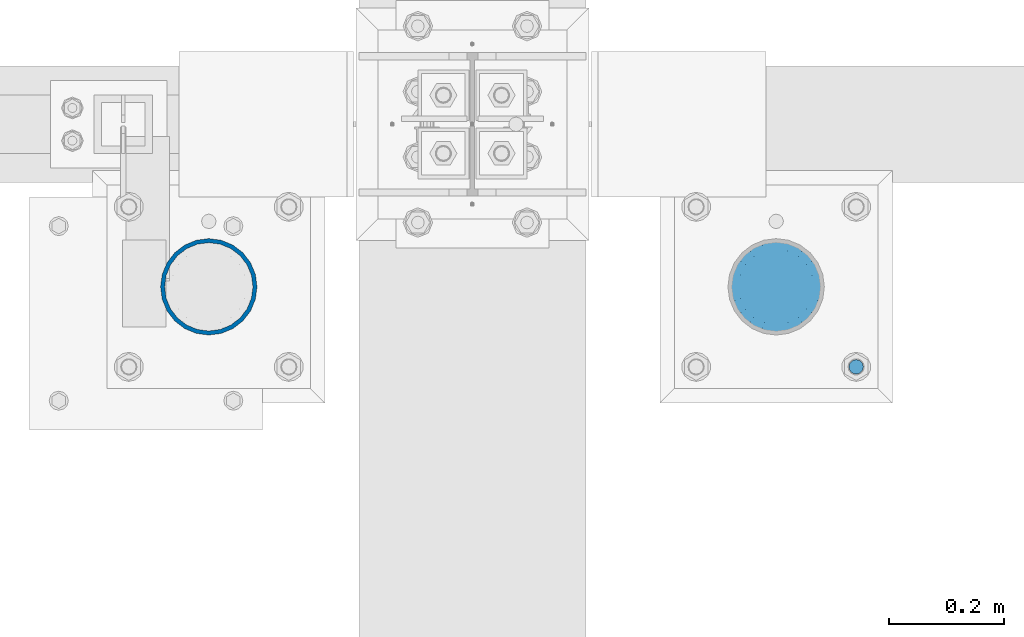
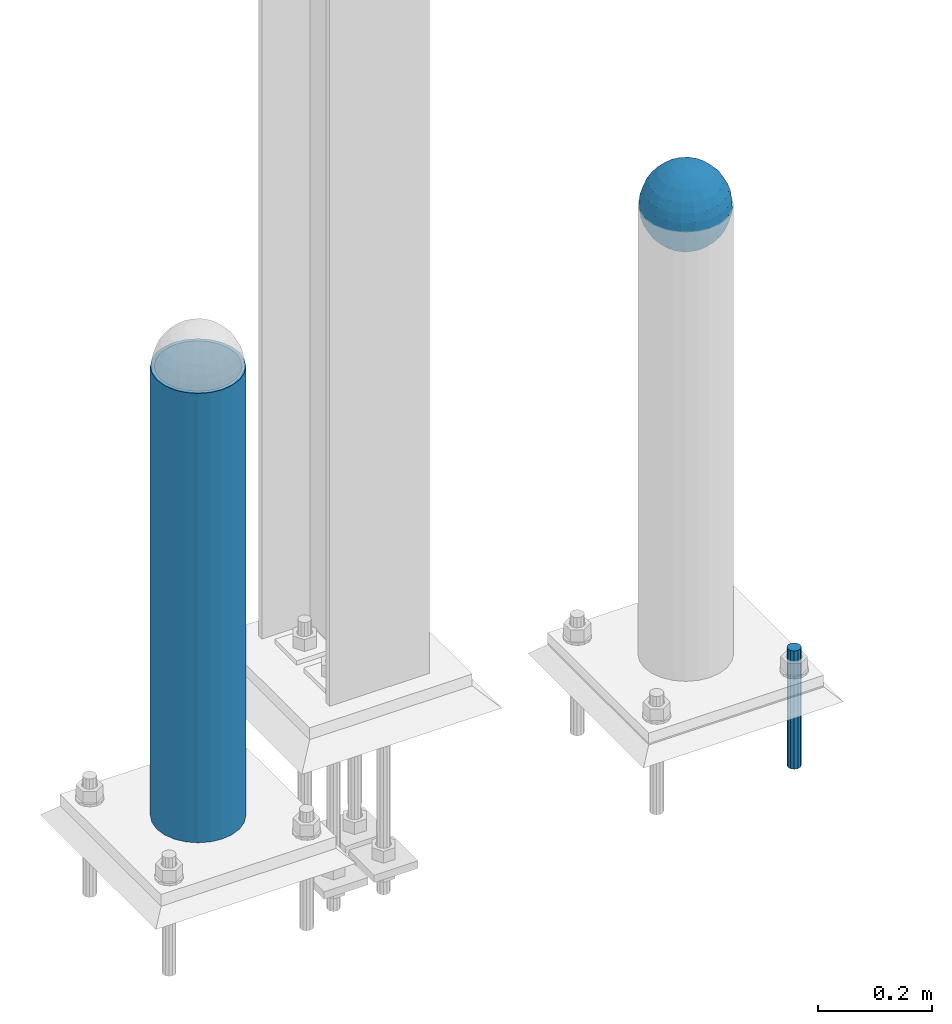
# One storey, part 1444 of 3843: 3 columns, 3 elements without a shape of their own.
"""IFC2X3 building model written with IfcOpenShell, lengths in millimetres."""

from ifc_helpers import new_model, si_unit, frame, origin_with_axes, place, context, subcontext, project, spatial, faceted_brep, material, type_object, element, aggregate, save


model = new_model("IFC2X3")

# Units and contexts
model_context = context("Model", 3, precision=1e-05, world=origin_with_axes())
body_context = subcontext(model_context, "Body", "Model", "MODEL_VIEW")
ifc_project = project(units=[si_unit("LENGTHUNIT", "METRE", prefix="MILLI"), si_unit("AREAUNIT", "SQUARE_METRE"), si_unit("VOLUMEUNIT", "CUBIC_METRE"), si_unit("MASSUNIT", "GRAM", prefix="KILO"), si_unit("TIMEUNIT", "SECOND"), si_unit("PLANEANGLEUNIT", "RADIAN"), si_unit("SOLIDANGLEUNIT", "STERADIAN"), si_unit("THERMODYNAMICTEMPERATUREUNIT", "DEGREE_CELSIUS"), si_unit("LUMINOUSINTENSITYUNIT", "LUMEN")], contexts=[model_context])

# Site, building, storey
site_placement = place(None, origin_with_axes())
site = spatial("IfcSite", under=ifc_project, at=site_placement, CompositionType="ELEMENT")
building_placement = place(site_placement, origin_with_axes())
building = spatial("IfcBuilding", under=site, at=building_placement, Name="Undefined", CompositionType="ELEMENT")
storey_placement = place(building_placement, origin_with_axes())
storey = spatial("IfcBuildingStorey", under=building, at=storey_placement, Name="Undefined", CompositionType="ELEMENT", Elevation=0.0)

# Assembly, column
assembly_1_placement = place(storey_placement, origin_with_axes())
assembly_1 = element("IfcElementAssembly", 1, at=assembly_1_placement, inside=storey, Name="CONC. FILL", AssemblyPlace="NOTDEFINED", PredefinedType="REINFORCEMENT_UNIT")
ifc_material_1 = material(Name="CONCRETE/1500")
column_type_1 = type_object("IfcColumnType", PredefinedType="NOTDEFINED")
column_1_placement = place(assembly_1_placement, frame((37106.2721557617, 14714.9457781578, 31411.8625), z_axis=(-1.0, 0.0, 0.0), x_axis=(0.0, 0.0, 1.0)))
column_1 = element("IfcColumn", 2, at=column_1_placement, type_object=column_type_1, material=ifc_material_1, Name="CONC. FILL", context=body_context, shape_type="Brep", body=[
    faceted_brep([(0.0, 0.0, 2.0), (0.0, -0.619999999995343, 1.89999999999964), (3.36549999999988, -7.1422259999963, 21.9814139999999), (3.36549999999988, 0.0, 23.1139999999996), (0.0, -1.17999999999302, 1.6200000000008), (3.36549999999988, -13.5910319999966, 18.6992260000006), (0.0, -1.61999999999534, 1.18000000000029), (3.36549999999988, -18.699225999997, 13.5910320000003), (0.0, -1.89999999999418, 0.6200000000008), (3.36549999999988, -21.9814139999944, 7.14222599999994), (0.0, -2.0, 0.0), (3.36549999999988, -23.1140000000014, 0.0), (0.0, -1.89999999999418, -0.6200000000008), (3.36549999999988, -21.9814139999944, -7.14222599999994), (0.0, -1.61999999999534, -1.18000000000029), (3.36549999999988, -18.699225999997, -13.5910320000003), (0.0, -1.17999999999302, -1.6200000000008), (3.36549999999988, -13.5910319999966, -18.6992260000006), (0.0, -0.619999999995343, -1.89999999999964), (3.36549999999988, -7.1422259999963, -21.9814139999999), (0.0, 0.0, -2.0), (3.36549999999988, 0.0, -23.1139999999996), (0.0, 0.619999999995343, -1.89999999999964), (3.36549999999988, 7.1422259999963, -21.9814139999999), (0.0, 1.17999999999302, -1.6200000000008), (3.36549999999988, 13.5910319999966, -18.6992260000006), (0.0, 1.61999999999534, -1.18000000000029), (3.36549999999988, 18.699225999997, -13.5910320000003), (0.0, 1.89999999999418, -0.6200000000008), (3.36549999999988, 21.9814139999944, -7.14222599999994), (0.0, 2.0, 0.0), (3.36549999999988, 23.1140000000014, 0.0), (0.0, 1.89999999999418, 0.6200000000008), (3.36549999999988, 21.9814139999944, 7.14222599999994), (0.0, 1.61999999999534, 1.18000000000029), (3.36549999999988, 18.699225999997, 13.5910320000003), (0.0, 1.17999999999302, 1.6200000000008), (3.36549999999988, 13.5910319999966, 18.6992260000006), (0.0, 0.619999999995343, 1.89999999999964), (3.36549999999988, 7.1422259999963, 21.9814139999999), (8.41374999999971, -11.1214661999984, 34.2282018000005), (8.41374999999971, 0.0, 35.9917999999998), (8.41374999999971, -21.1631784000056, 29.1173662000001), (8.41374999999971, -29.1173661999928, 21.1631784000001), (8.41374999999971, -34.2282017999969, 11.1214662000002), (8.41374999999971, -35.9918000000034, 0.0), (8.41374999999971, -34.2282017999969, -11.1214662000002), (8.41374999999971, -29.1173661999928, -21.1631784000001), (8.41374999999971, -21.1631784000056, -29.1173662000001), (8.41374999999971, -11.1214661999984, -34.2282018000005), (8.41374999999971, 0.0, -35.9917999999998), (8.41374999999971, 11.1214661999984, -34.2282018000005), (8.41374999999971, 21.1631784000056, -29.1173662000001), (8.41374999999971, 29.1173661999928, -21.1631784000001), (8.41374999999971, 34.2282017999969, -11.1214662000002), (8.41374999999971, 35.9918000000034, 0.0), (8.41374999999971, 34.2282017999969, 11.1214662000002), (8.41374999999971, 29.1173661999928, 21.1631784000001), (8.41374999999971, 21.1631784000056, 29.1173662000001), (8.41374999999971, 11.1214661999984, 34.2282018000005), (16.8274999999994, -15.3047700000025, 47.1030300000002), (16.8274999999994, 0.0, 49.5300000000007), (16.8274999999994, -29.1236400000053, 40.0697700000001), (16.8274999999994, -40.0697700000019, 29.1236399999998), (16.8274999999994, -47.1030299999984, 15.3047700000006), (16.8274999999994, -49.5299999999988, 0.0), (16.8274999999994, -47.1030299999984, -15.3047700000006), (16.8274999999994, -40.0697700000019, -29.1236399999998), (16.8274999999994, -29.1236400000053, -40.0697700000001), (16.8274999999994, -15.3047700000025, -47.1030300000002), (16.8274999999994, 0.0, -49.5300000000007), (16.8274999999994, 15.3047700000025, -47.1030300000002), (16.8274999999994, 29.1236400000053, -40.0697700000001), (16.8274999999994, 40.0697700000019, -29.1236399999998), (16.8274999999994, 47.1030299999984, -15.3047700000006), (16.8274999999994, 49.5299999999988, 0.0), (16.8274999999994, 47.1030299999984, 15.3047700000006), (16.8274999999994, 40.0697700000019, 29.1236399999998), (16.8274999999994, 29.1236400000053, 40.0697700000001), (16.8274999999994, 15.3047700000025, 47.1030300000002), (33.6549999999988, -20.4063599999936, 62.8040400000009), (33.6549999999988, 0.0, 66.0400000000009), (33.6549999999988, -38.831520000007, 53.4263599999995), (33.6549999999988, -53.4263599999977, 38.8315199999997), (33.6549999999988, -62.8040400000027, 20.4063600000009), (33.6549999999988, -66.0399999999936, 0.0), (33.6549999999988, -62.8040400000027, -20.4063600000009), (33.6549999999988, -53.4263599999977, -38.8315199999997), (33.6549999999988, -38.831520000007, -53.4263599999995), (33.6549999999988, -20.4063599999936, -62.8040400000009), (33.6549999999988, 0.0, -66.0400000000009), (33.6549999999988, 20.4063599999936, -62.8040400000009), (33.6549999999988, 38.831520000007, -53.4263599999995), (33.6549999999988, 53.4263599999977, -38.8315199999997), (33.6549999999988, 62.8040400000027, -20.4063600000009), (33.6549999999988, 66.0399999999936, 0.0), (33.6549999999988, 62.8040400000027, 20.4063600000009), (33.6549999999988, 53.4263599999977, 38.8315199999997), (33.6549999999988, 38.831520000007, 53.4263599999995), (33.6549999999988, 20.4063599999936, 62.8040400000009), (50.4824999999983, -23.3907901500061, 71.9891308499991), (50.4824999999983, 0.0, 75.6983500000006), (50.4824999999983, -44.5106298000028, 61.23996515), (50.4824999999983, -61.2399651500018, 44.5106297999992), (50.4824999999983, -71.9891308499937, 23.3907901500006), (50.4824999999983, -75.698350000006, 0.0), (50.4824999999983, -71.9891308499937, -23.3907901500006), (50.4824999999983, -61.2399651500018, -44.5106297999992), (50.4824999999983, -44.5106298000028, -61.23996515), (50.4824999999983, -23.3907901500061, -71.9891308499991), (50.4824999999983, 0.0, -75.6983500000006), (50.4824999999983, 23.3907901500061, -71.9891308499991), (50.4824999999983, 44.5106298000028, -61.23996515), (50.4824999999983, 61.2399651500018, -44.5106297999992), (50.4824999999983, 71.9891308499937, -23.3907901500006), (50.4824999999983, 75.698350000006, 0.0), (50.4824999999983, 71.9891308499937, 23.3907901500006), (50.4824999999983, 61.2399651500018, 44.5106297999992), (50.4824999999983, 44.5106298000028, 61.23996515), (50.4824999999983, 23.3907901500061, 71.9891308499991), (67.3099999999977, -24.9977910000016, 76.9349490000004), (67.3099999999977, 0.0, 80.8989999999994), (67.3099999999977, -47.5686120000028, 65.4472910000004), (67.3099999999977, -65.447291000004, 47.5686119999991), (67.3099999999977, -76.9349490000022, 24.9977909999998), (67.3099999999977, -80.8990000000049, 0.0), (67.3099999999977, -76.9349490000022, -24.9977909999998), (67.3099999999977, -65.447291000004, -47.5686119999991), (67.3099999999977, -47.5686120000028, -65.4472910000004), (67.3099999999977, -24.9977910000016, -76.9349490000004), (67.3099999999977, 0.0, -80.8989999999994), (67.3099999999977, 24.9977910000016, -76.9349490000004), (67.3099999999977, 47.5686120000028, -65.4472910000004), (67.3099999999977, 65.447291000004, -47.5686119999991), (67.3099999999977, 76.9349490000022, -24.9977909999998), (67.3099999999977, 80.8990000000049, 0.0), (67.3099999999977, 76.9349490000022, 24.9977909999998), (67.3099999999977, 65.447291000004, 47.5686119999991), (67.3099999999977, 47.5686120000028, 65.4472910000004), (67.3099999999977, 24.9977910000016, 76.9349490000004), (84.1374999999935, -25.5079499999993, 78.5050499999998), (84.1374999999935, 0.0, 82.5499999999993), (84.1374999999935, -48.5393999999942, 66.7829500000007), (84.1374999999935, -66.7829499999934, 48.5393999999997), (84.1374999999935, -78.505050000007, 25.5079499999993), (84.1374999999935, -82.5500000000029, 0.0), (84.1374999999935, -78.505050000007, -25.5079499999993), (84.1374999999935, -66.7829499999934, -48.5393999999997), (84.1374999999935, -48.5393999999942, -66.7829500000007), (84.1374999999935, -25.5079499999993, -78.5050499999998), (84.1374999999935, 0.0, -82.5499999999993), (84.1374999999935, 25.5079499999993, -78.5050499999998), (84.1374999999935, 48.5393999999942, -66.7829500000007), (84.1374999999935, 66.7829499999934, -48.5393999999997), (84.1374999999935, 78.505050000007, -25.5079499999993), (84.1374999999935, 82.5500000000029, 0.0), (84.1374999999935, 78.505050000007, 25.5079499999993), (84.1374999999935, 66.7829499999934, 48.5393999999997), (84.1374999999935, 48.5393999999942, 66.7829500000007), (84.1374999999935, 25.5079499999993, 78.5050499999998), (100.964999999993, -24.9977910000016, 76.9349490000004), (100.964999999993, 0.0, 80.8989999999994), (100.964999999993, -47.5686120000028, 65.4472910000004), (100.964999999993, -65.447291000004, 47.5686119999991), (100.964999999993, -76.9349490000022, 24.9977909999998), (100.964999999993, -80.8990000000049, 0.0), (100.964999999993, -76.9349490000022, -24.9977909999998), (100.964999999993, -65.447291000004, -47.5686119999991), (100.964999999993, -47.5686120000028, -65.4472910000004), (100.964999999993, -24.9977910000016, -76.9349490000004), (100.964999999993, 0.0, -80.8989999999994), (100.964999999993, 24.9977910000016, -76.9349490000004), (100.964999999993, 47.5686120000028, -65.4472910000004), (100.964999999993, 65.447291000004, -47.5686119999991), (100.964999999993, 76.9349490000022, -24.9977909999998), (100.964999999993, 80.8990000000049, 0.0), (100.964999999993, 76.9349490000022, 24.9977909999998), (100.964999999993, 65.447291000004, 47.5686119999991), (100.964999999993, 47.5686120000028, 65.4472910000004), (100.964999999993, 24.9977910000016, 76.9349490000004), (117.792499999992, -23.3907901500061, 71.9891308499991), (117.792499999992, 0.0, 75.6983500000006), (117.792499999992, -44.5106298000028, 61.23996515), (117.792499999992, -61.2399651500018, 44.5106297999992), (117.792499999992, -71.9891308499937, 23.3907901500006), (117.792499999992, -75.698350000006, 0.0), (117.792499999992, -71.9891308499937, -23.3907901500006), (117.792499999992, -61.2399651500018, -44.5106297999992), (117.792499999992, -44.5106298000028, -61.23996515), (117.792499999992, -23.3907901500061, -71.9891308499991), (117.792499999992, 0.0, -75.6983500000006), (117.792499999992, 23.3907901500061, -71.9891308499991), (117.792499999992, 44.5106298000028, -61.23996515), (117.792499999992, 61.2399651500018, -44.5106297999992), (117.792499999992, 71.9891308499937, -23.3907901500006), (117.792499999992, 75.698350000006, 0.0), (117.792499999992, 71.9891308499937, 23.3907901500006), (117.792499999992, 61.2399651500018, 44.5106297999992), (117.792499999992, 44.5106298000028, 61.23996515), (117.792499999992, 23.3907901500061, 71.9891308499991), (134.619999999992, -20.4063599999936, 62.8040400000009), (134.619999999992, 0.0, 66.0400000000009), (134.619999999992, -38.831520000007, 53.4263599999995), (134.619999999992, -53.4263599999977, 38.8315199999997), (134.619999999992, -62.8040400000027, 20.4063600000009), (134.619999999992, -66.0399999999936, 0.0), (134.619999999992, -62.8040400000027, -20.4063600000009), (134.619999999992, -53.4263599999977, -38.8315199999997), (134.619999999992, -38.831520000007, -53.4263599999995), (134.619999999992, -20.4063599999936, -62.8040400000009), (134.619999999992, 0.0, -66.0400000000009), (134.619999999992, 20.4063599999936, -62.8040400000009), (134.619999999992, 38.831520000007, -53.4263599999995), (134.619999999992, 53.4263599999977, -38.8315199999997), (134.619999999992, 62.8040400000027, -20.4063600000009), (134.619999999992, 66.0399999999936, 0.0), (134.619999999992, 62.8040400000027, 20.4063600000009), (134.619999999992, 53.4263599999977, 38.8315199999997), (134.619999999992, 38.831520000007, 53.4263599999995), (134.619999999992, 20.4063599999936, 62.8040400000009), (151.447499999991, -15.3047700000025, 47.1030300000002), (151.447499999991, 0.0, 49.5300000000007), (151.447499999991, -29.1236400000053, 40.0697700000001), (151.447499999991, -40.0697700000019, 29.1236399999998), (151.447499999991, -47.1030299999984, 15.3047700000006), (151.447499999991, -49.5299999999988, 0.0), (151.447499999991, -47.1030299999984, -15.3047700000006), (151.447499999991, -40.0697700000019, -29.1236399999998), (151.447499999991, -29.1236400000053, -40.0697700000001), (151.447499999991, -15.3047700000025, -47.1030300000002), (151.447499999991, 0.0, -49.5300000000007), (151.447499999991, 15.3047700000025, -47.1030300000002), (151.447499999991, 29.1236400000053, -40.0697700000001), (151.447499999991, 40.0697700000019, -29.1236399999998), (151.447499999991, 47.1030299999984, -15.3047700000006), (151.447499999991, 49.5299999999988, 0.0), (151.447499999991, 47.1030299999984, 15.3047700000006), (151.447499999991, 40.0697700000019, 29.1236399999998), (151.447499999991, 29.1236400000053, 40.0697700000001), (151.447499999991, 15.3047700000025, 47.1030300000002), (159.861249999991, -11.1214661999984, 34.2282018000005), (159.861249999991, 0.0, 35.9917999999998), (159.861249999991, -21.1631784000056, 29.1173662000001), (159.861249999991, -29.1173661999928, 21.1631784000001), (159.861249999991, -34.2282017999969, 11.1214662000002), (159.861249999991, -35.9918000000034, 0.0), (159.861249999991, -34.2282017999969, -11.1214662000002), (159.861249999991, -29.1173661999928, -21.1631784000001), (159.861249999991, -21.1631784000056, -29.1173662000001), (159.861249999991, -11.1214661999984, -34.2282018000005), (159.861249999991, 0.0, -35.9917999999998), (159.861249999991, 11.1214661999984, -34.2282018000005), (159.861249999991, 21.1631784000056, -29.1173662000001), (159.861249999991, 29.1173661999928, -21.1631784000001), (159.861249999991, 34.2282017999969, -11.1214662000002), (159.861249999991, 35.9918000000034, 0.0), (159.861249999991, 34.2282017999969, 11.1214662000002), (159.861249999991, 29.1173661999928, 21.1631784000001), (159.861249999991, 21.1631784000056, 29.1173662000001), (159.861249999991, 11.1214661999984, 34.2282018000005), (164.909499999991, -7.1422259999963, 21.9814139999999), (164.909499999991, 0.0, 23.1139999999996), (164.909499999991, -13.5910319999966, 18.6992260000006), (164.909499999991, -18.699225999997, 13.5910320000003), (164.909499999991, -21.9814139999944, 7.14222599999994), (164.909499999991, -23.1140000000014, 0.0), (164.909499999991, -21.9814139999944, -7.14222599999994), (164.909499999991, -18.699225999997, -13.5910320000003), (164.909499999991, -13.5910319999966, -18.6992260000006), (164.909499999991, -7.1422259999963, -21.9814139999999), (164.909499999991, 0.0, -23.1139999999996), (164.909499999991, 7.1422259999963, -21.9814139999999), (164.909499999991, 13.5910319999966, -18.6992260000006), (164.909499999991, 18.699225999997, -13.5910320000003), (164.909499999991, 21.9814139999944, -7.14222599999994), (164.909499999991, 23.1140000000014, 0.0), (164.909499999991, 21.9814139999944, 7.14222599999994), (164.909499999991, 18.699225999997, 13.5910320000003), (164.909499999991, 13.5910319999966, 18.6992260000006), (164.909499999991, 7.1422259999963, 21.9814139999999), (168.274999999991, -0.619999999995343, 1.89999999999964), (168.274999999991, 0.0, 2.0), (168.274999999991, -1.17999999999302, 1.6200000000008), (168.274999999991, -1.61999999999534, 1.18000000000029), (168.274999999991, -1.89999999999418, 0.6200000000008), (168.274999999991, -2.0, 0.0), (168.274999999991, -1.89999999999418, -0.6200000000008), (168.274999999991, -1.61999999999534, -1.18000000000029), (168.274999999991, -1.17999999999302, -1.6200000000008), (168.274999999991, -0.619999999995343, -1.89999999999964), (168.274999999991, 0.0, -2.0), (168.274999999991, 0.619999999995343, -1.89999999999964), (168.274999999991, 1.17999999999302, -1.6200000000008), (168.274999999991, 1.61999999999534, -1.18000000000029), (168.274999999991, 1.89999999999418, -0.6200000000008), (168.274999999991, 2.0, 0.0), (168.274999999991, 1.89999999999418, 0.6200000000008), (168.274999999991, 1.61999999999534, 1.18000000000029), (168.274999999991, 1.17999999999302, 1.6200000000008), (168.274999999991, 0.619999999995343, 1.89999999999964)], [[[0, 1, 2, 3]], [[1, 4, 5, 2]], [[4, 6, 7, 5]], [[6, 8, 9, 7]], [[8, 10, 11, 9]], [[10, 12, 13, 11]], [[12, 14, 15, 13]], [[14, 16, 17, 15]], [[16, 18, 19, 17]], [[18, 20, 21, 19]], [[20, 22, 23, 21]], [[22, 24, 25, 23]], [[24, 26, 27, 25]], [[26, 28, 29, 27]], [[28, 30, 31, 29]], [[30, 32, 33, 31]], [[32, 34, 35, 33]], [[34, 36, 37, 35]], [[36, 38, 39, 37]], [[38, 0, 3, 39]], [[38, 36, 34, 32, 30, 28, 26, 24, 22, 20, 18, 16, 14, 12, 10, 8, 6, 4, 1, 0]], [[3, 2, 40, 41]], [[2, 5, 42, 40]], [[5, 7, 43, 42]], [[7, 9, 44, 43]], [[9, 11, 45, 44]], [[11, 13, 46, 45]], [[13, 15, 47, 46]], [[15, 17, 48, 47]], [[17, 19, 49, 48]], [[19, 21, 50, 49]], [[21, 23, 51, 50]], [[23, 25, 52, 51]], [[25, 27, 53, 52]], [[27, 29, 54, 53]], [[29, 31, 55, 54]], [[31, 33, 56, 55]], [[33, 35, 57, 56]], [[35, 37, 58, 57]], [[37, 39, 59, 58]], [[39, 3, 41, 59]], [[41, 40, 60, 61]], [[40, 42, 62, 60]], [[42, 43, 63, 62]], [[43, 44, 64, 63]], [[44, 45, 65, 64]], [[45, 46, 66, 65]], [[46, 47, 67, 66]], [[47, 48, 68, 67]], [[48, 49, 69, 68]], [[49, 50, 70, 69]], [[50, 51, 71, 70]], [[51, 52, 72, 71]], [[52, 53, 73, 72]], [[53, 54, 74, 73]], [[54, 55, 75, 74]], [[55, 56, 76, 75]], [[56, 57, 77, 76]], [[57, 58, 78, 77]], [[58, 59, 79, 78]], [[59, 41, 61, 79]], [[61, 60, 80, 81]], [[60, 62, 82, 80]], [[62, 63, 83, 82]], [[63, 64, 84, 83]], [[64, 65, 85, 84]], [[65, 66, 86, 85]], [[66, 67, 87, 86]], [[67, 68, 88, 87]], [[68, 69, 89, 88]], [[69, 70, 90, 89]], [[70, 71, 91, 90]], [[71, 72, 92, 91]], [[72, 73, 93, 92]], [[73, 74, 94, 93]], [[74, 75, 95, 94]], [[75, 76, 96, 95]], [[76, 77, 97, 96]], [[77, 78, 98, 97]], [[78, 79, 99, 98]], [[79, 61, 81, 99]], [[81, 80, 100, 101]], [[80, 82, 102, 100]], [[82, 83, 103, 102]], [[83, 84, 104, 103]], [[84, 85, 105, 104]], [[85, 86, 106, 105]], [[86, 87, 107, 106]], [[87, 88, 108, 107]], [[88, 89, 109, 108]], [[89, 90, 110, 109]], [[90, 91, 111, 110]], [[91, 92, 112, 111]], [[92, 93, 113, 112]], [[93, 94, 114, 113]], [[94, 95, 115, 114]], [[95, 96, 116, 115]], [[96, 97, 117, 116]], [[97, 98, 118, 117]], [[98, 99, 119, 118]], [[99, 81, 101, 119]], [[101, 100, 120, 121]], [[100, 102, 122, 120]], [[102, 103, 123, 122]], [[103, 104, 124, 123]], [[104, 105, 125, 124]], [[105, 106, 126, 125]], [[106, 107, 127, 126]], [[107, 108, 128, 127]], [[108, 109, 129, 128]], [[109, 110, 130, 129]], [[110, 111, 131, 130]], [[111, 112, 132, 131]], [[112, 113, 133, 132]], [[113, 114, 134, 133]], [[114, 115, 135, 134]], [[115, 116, 136, 135]], [[116, 117, 137, 136]], [[117, 118, 138, 137]], [[118, 119, 139, 138]], [[119, 101, 121, 139]], [[121, 120, 140, 141]], [[120, 122, 142, 140]], [[122, 123, 143, 142]], [[123, 124, 144, 143]], [[124, 125, 145, 144]], [[125, 126, 146, 145]], [[126, 127, 147, 146]], [[127, 128, 148, 147]], [[128, 129, 149, 148]], [[129, 130, 150, 149]], [[130, 131, 151, 150]], [[131, 132, 152, 151]], [[132, 133, 153, 152]], [[133, 134, 154, 153]], [[134, 135, 155, 154]], [[135, 136, 156, 155]], [[136, 137, 157, 156]], [[137, 138, 158, 157]], [[138, 139, 159, 158]], [[139, 121, 141, 159]], [[141, 140, 160, 161]], [[140, 142, 162, 160]], [[142, 143, 163, 162]], [[143, 144, 164, 163]], [[144, 145, 165, 164]], [[145, 146, 166, 165]], [[146, 147, 167, 166]], [[147, 148, 168, 167]], [[148, 149, 169, 168]], [[149, 150, 170, 169]], [[150, 151, 171, 170]], [[151, 152, 172, 171]], [[152, 153, 173, 172]], [[153, 154, 174, 173]], [[154, 155, 175, 174]], [[155, 156, 176, 175]], [[156, 157, 177, 176]], [[157, 158, 178, 177]], [[158, 159, 179, 178]], [[159, 141, 161, 179]], [[161, 160, 180, 181]], [[160, 162, 182, 180]], [[162, 163, 183, 182]], [[163, 164, 184, 183]], [[164, 165, 185, 184]], [[165, 166, 186, 185]], [[166, 167, 187, 186]], [[167, 168, 188, 187]], [[168, 169, 189, 188]], [[169, 170, 190, 189]], [[170, 171, 191, 190]], [[171, 172, 192, 191]], [[172, 173, 193, 192]], [[173, 174, 194, 193]], [[174, 175, 195, 194]], [[175, 176, 196, 195]], [[176, 177, 197, 196]], [[177, 178, 198, 197]], [[178, 179, 199, 198]], [[179, 161, 181, 199]], [[181, 180, 200, 201]], [[180, 182, 202, 200]], [[182, 183, 203, 202]], [[183, 184, 204, 203]], [[184, 185, 205, 204]], [[185, 186, 206, 205]], [[186, 187, 207, 206]], [[187, 188, 208, 207]], [[188, 189, 209, 208]], [[189, 190, 210, 209]], [[190, 191, 211, 210]], [[191, 192, 212, 211]], [[192, 193, 213, 212]], [[193, 194, 214, 213]], [[194, 195, 215, 214]], [[195, 196, 216, 215]], [[196, 197, 217, 216]], [[197, 198, 218, 217]], [[198, 199, 219, 218]], [[199, 181, 201, 219]], [[201, 200, 220, 221]], [[200, 202, 222, 220]], [[202, 203, 223, 222]], [[203, 204, 224, 223]], [[204, 205, 225, 224]], [[205, 206, 226, 225]], [[206, 207, 227, 226]], [[207, 208, 228, 227]], [[208, 209, 229, 228]], [[209, 210, 230, 229]], [[210, 211, 231, 230]], [[211, 212, 232, 231]], [[212, 213, 233, 232]], [[213, 214, 234, 233]], [[214, 215, 235, 234]], [[215, 216, 236, 235]], [[216, 217, 237, 236]], [[217, 218, 238, 237]], [[218, 219, 239, 238]], [[219, 201, 221, 239]], [[221, 220, 240, 241]], [[220, 222, 242, 240]], [[222, 223, 243, 242]], [[223, 224, 244, 243]], [[224, 225, 245, 244]], [[225, 226, 246, 245]], [[226, 227, 247, 246]], [[227, 228, 248, 247]], [[228, 229, 249, 248]], [[229, 230, 250, 249]], [[230, 231, 251, 250]], [[231, 232, 252, 251]], [[232, 233, 253, 252]], [[233, 234, 254, 253]], [[234, 235, 255, 254]], [[235, 236, 256, 255]], [[236, 237, 257, 256]], [[237, 238, 258, 257]], [[238, 239, 259, 258]], [[239, 221, 241, 259]], [[241, 240, 260, 261]], [[240, 242, 262, 260]], [[242, 243, 263, 262]], [[243, 244, 264, 263]], [[244, 245, 265, 264]], [[245, 246, 266, 265]], [[246, 247, 267, 266]], [[247, 248, 268, 267]], [[248, 249, 269, 268]], [[249, 250, 270, 269]], [[250, 251, 271, 270]], [[251, 252, 272, 271]], [[252, 253, 273, 272]], [[253, 254, 274, 273]], [[254, 255, 275, 274]], [[255, 256, 276, 275]], [[256, 257, 277, 276]], [[257, 258, 278, 277]], [[258, 259, 279, 278]], [[259, 241, 261, 279]], [[261, 260, 280, 281]], [[260, 262, 282, 280]], [[262, 263, 283, 282]], [[263, 264, 284, 283]], [[264, 265, 285, 284]], [[265, 266, 286, 285]], [[266, 267, 287, 286]], [[267, 268, 288, 287]], [[268, 269, 289, 288]], [[269, 270, 290, 289]], [[270, 271, 291, 290]], [[271, 272, 292, 291]], [[272, 273, 293, 292]], [[273, 274, 294, 293]], [[274, 275, 295, 294]], [[275, 276, 296, 295]], [[276, 277, 297, 296]], [[277, 278, 298, 297]], [[278, 279, 299, 298]], [[279, 261, 281, 299]], [[282, 283, 284, 285, 286, 287, 288, 289, 290, 291, 292, 293, 294, 295, 296, 297, 298, 299, 281, 280]]]),
])
aggregate(assembly_1, [column_1])

assembly_2_placement = place(storey_placement, origin_with_axes())
assembly_2 = element("IfcElementAssembly", 3, at=assembly_2_placement, inside=storey, Name="PIPE_BOLLARD", AssemblyPlace="NOTDEFINED", PredefinedType="RIGID_FRAME")
ifc_material_2 = material()
column_type_2 = type_object("IfcColumnType", Name="PIPE6SCH40", PredefinedType="NOTDEFINED")
column_2_placement = place(assembly_2_placement, frame((36115.6715698242, 14714.9457781578, 30480.0), z_axis=(-1.0, 0.0, 0.0), x_axis=(0.0, 0.0, 1.0)))
column_2 = element("IfcColumn", 4, at=column_2_placement, type_object=column_type_2, material=ifc_material_2, Name="PIPE_BOLLARD", ObjectType="PIPE6SCH40", context=body_context, shape_type="Brep", body=[
    faceted_brep([(50.7999999999993, -77.0890000000072, 0.0), (50.7999999999993, -74.4622560228017, 19.9521013679114), (1016.0, -74.4622560228017, 19.9521013679114), (1016.0, -77.0890000000072, 0.0), (50.7999999999993, -66.7610323523404, 38.5445000000036), (1016.0, -66.7610323523404, 38.5445000000036), (50.7999999999993, -54.5101546548831, 54.5101546548904), (1016.0, -54.5101546548831, 54.5101546548904), (50.7999999999993, -38.5445000000036, 66.7610323523404), (1016.0, -38.5445000000036, 66.7610323523404), (50.7999999999993, -19.9521013679041, 74.4622560227945), (1016.0, -19.9521013679041, 74.4622560227945), (50.7999999999993, 0.0, 77.0889999999999), (1016.0, 0.0, 77.0889999999999), (50.7999999999993, 19.9521013679041, 74.4622560227945), (1016.0, 19.9521013679041, 74.4622560227945), (50.7999999999993, 38.5445000000036, 66.7610323523404), (1016.0, 38.5445000000036, 66.7610323523404), (50.7999999999993, 54.5101546548831, 54.5101546548904), (1016.0, 54.5101546548831, 54.5101546548904), (50.7999999999993, 66.7610323523404, 38.5445000000036), (1016.0, 66.7610323523404, 38.5445000000036), (50.7999999999993, 74.4622560228017, 19.9521013679114), (1016.0, 74.4622560228017, 19.9521013679114), (50.7999999999993, 77.0890000000072, 0.0), (1016.0, 77.0890000000072, 0.0), (50.7999999999993, 74.4622560228017, -19.9521013679114), (1016.0, 74.4622560228017, -19.9521013679114), (50.7999999999993, 66.7610323523404, -38.5445000000036), (1016.0, 66.7610323523404, -38.5445000000036), (50.7999999999993, 54.5101546548831, -54.5101546548904), (1016.0, 54.5101546548831, -54.5101546548904), (50.7999999999993, 38.5445000000036, -66.7610323523404), (1016.0, 38.5445000000036, -66.7610323523404), (50.7999999999993, 19.9521013679041, -74.4622560227945), (1016.0, 19.9521013679041, -74.4622560227945), (50.7999999999993, 0.0, -77.0889999999999), (1016.0, 0.0, -77.0889999999999), (50.7999999999993, -19.9521013679041, -74.4622560227945), (1016.0, -19.9521013679041, -74.4622560227945), (50.7999999999993, -38.5445000000036, -66.7610323523404), (1016.0, -38.5445000000036, -66.7610323523404), (50.7999999999993, -54.5101546548831, -54.5101546548904), (1016.0, -54.5101546548831, -54.5101546548904), (50.7999999999993, -66.7610323523404, -38.5445000000036), (1016.0, -66.7610323523404, -38.5445000000036), (50.7999999999993, -74.4622560228017, -19.9521013679114), (1016.0, -74.4622560228017, -19.9521013679114), (50.7999999999993, -84.2010000000009, 0.0), (50.7999999999993, -81.3319204993604, -21.7928224166753), (1016.0, -81.3319204993604, -21.7928224166753), (1016.0, -84.2010000000009, 0.0), (50.7999999999993, -72.9202050240565, -42.1005000000005), (1016.0, -72.9202050240565, -42.1005000000005), (50.7999999999993, -59.5390980826924, -59.5390980826851), (1016.0, -59.5390980826924, -59.5390980826851), (50.7999999999993, -42.1005000000005, -72.9202050240565), (1016.0, -42.1005000000005, -72.9202050240565), (50.7999999999993, -21.7928224166826, -81.3319204993677), (1016.0, -21.7928224166826, -81.3319204993677), (50.7999999999993, 0.0, -84.2010000000009), (1016.0, 0.0, -84.2010000000009), (50.7999999999993, 21.7928224166826, -81.3319204993677), (1016.0, 21.7928224166826, -81.3319204993677), (50.7999999999993, 42.1005000000005, -72.9202050240565), (1016.0, 42.1005000000005, -72.9202050240565), (50.7999999999993, 59.5390980826924, -59.5390980826851), (1016.0, 59.5390980826924, -59.5390980826851), (50.7999999999993, 72.9202050240565, -42.1005000000005), (1016.0, 72.9202050240565, -42.1005000000005), (50.7999999999993, 81.3319204993604, -21.7928224166753), (1016.0, 81.3319204993604, -21.7928224166753), (50.7999999999993, 84.2010000000009, 0.0), (1016.0, 84.2010000000009, 0.0), (50.7999999999993, 81.3319204993604, 21.7928224166753), (1016.0, 81.3319204993604, 21.7928224166753), (50.7999999999993, 72.9202050240565, 42.1005000000005), (1016.0, 72.9202050240565, 42.1005000000005), (50.7999999999993, 59.5390980826924, 59.5390980826851), (1016.0, 59.5390980826924, 59.5390980826851), (50.7999999999993, 42.1005000000005, 72.9202050240565), (1016.0, 42.1005000000005, 72.9202050240565), (50.7999999999993, 21.7928224166826, 81.3319204993677), (1016.0, 21.7928224166826, 81.3319204993677), (50.7999999999993, 0.0, 84.2010000000009), (1016.0, 0.0, 84.2010000000009), (50.7999999999993, -21.7928224166826, 81.3319204993677), (1016.0, -21.7928224166826, 81.3319204993677), (50.7999999999993, -42.1005000000005, 72.9202050240565), (1016.0, -42.1005000000005, 72.9202050240565), (50.7999999999993, -59.5390980826924, 59.5390980826851), (1016.0, -59.5390980826924, 59.5390980826851), (50.7999999999993, -72.9202050240565, 42.1005000000005), (1016.0, -72.9202050240565, 42.1005000000005), (50.7999999999993, -81.3319204993604, 21.7928224166753), (1016.0, -81.3319204993604, 21.7928224166753)], [[[0, 1, 2, 3]], [[1, 4, 5, 2]], [[4, 6, 7, 5]], [[6, 8, 9, 7]], [[8, 10, 11, 9]], [[10, 12, 13, 11]], [[12, 14, 15, 13]], [[14, 16, 17, 15]], [[16, 18, 19, 17]], [[18, 20, 21, 19]], [[20, 22, 23, 21]], [[22, 24, 25, 23]], [[24, 26, 27, 25]], [[26, 28, 29, 27]], [[28, 30, 31, 29]], [[30, 32, 33, 31]], [[32, 34, 35, 33]], [[34, 36, 37, 35]], [[36, 38, 39, 37]], [[38, 40, 41, 39]], [[40, 42, 43, 41]], [[42, 44, 45, 43]], [[44, 46, 47, 45]], [[46, 0, 3, 47]], [[48, 49, 50, 51]], [[49, 52, 53, 50]], [[52, 54, 55, 53]], [[54, 56, 57, 55]], [[56, 58, 59, 57]], [[58, 60, 61, 59]], [[60, 62, 63, 61]], [[62, 64, 65, 63]], [[64, 66, 67, 65]], [[66, 68, 69, 67]], [[68, 70, 71, 69]], [[70, 72, 73, 71]], [[72, 74, 75, 73]], [[74, 76, 77, 75]], [[76, 78, 79, 77]], [[78, 80, 81, 79]], [[80, 82, 83, 81]], [[82, 84, 85, 83]], [[84, 86, 87, 85]], [[86, 88, 89, 87]], [[88, 90, 91, 89]], [[90, 92, 93, 91]], [[92, 94, 95, 93]], [[94, 48, 51, 95]], [[53, 55, 57, 59, 61, 63, 65, 67, 69, 71, 73, 75, 77, 79, 81, 83, 85, 87, 89, 91, 93, 95, 51, 50], [5, 7, 9, 11, 13, 15, 17, 19, 21, 23, 25, 27, 29, 31, 33, 35, 37, 39, 41, 43, 45, 47, 3, 2]], [[94, 92, 90, 88, 86, 84, 82, 80, 78, 76, 74, 72, 70, 68, 66, 64, 62, 60, 58, 56, 54, 52, 49, 48], [46, 44, 42, 40, 38, 36, 34, 32, 30, 28, 26, 24, 22, 20, 18, 16, 14, 12, 10, 8, 6, 4, 1, 0]]]),
])
aggregate(assembly_2, [column_2])

assembly_3_placement = place(storey_placement, origin_with_axes())
assembly_3 = element("IfcElementAssembly", 5, at=assembly_3_placement, inside=storey, Name="TEMPLATE", AssemblyPlace="NOTDEFINED", PredefinedType="RIGID_FRAME")
ifc_material_3 = material(Name="STEEL/316 SS")
column_type_3 = type_object("IfcColumnType", PredefinedType="NOTDEFINED")
column_3_placement = place(assembly_3_placement, frame((37245.9721557617, 14575.2457781578, 30581.6), z_axis=(1.0, 0.0, 0.0), x_axis=(0.0, 0.0, -1.0)))
column_3 = element("IfcColumn", 6, at=column_3_placement, type_object=column_type_3, material=ifc_material_3, Name="ANCHOR_ROD", context=body_context, shape_type="Brep", body=[
    faceted_brep([(0.0, -12.6999999999971, 0.0), (0.0, -10.9985226280696, -6.34999999999854), (253.999, -10.9985226280696, -6.34999999999854), (253.999, -12.6999999999971, 0.0), (0.0, -6.35000000000582, -10.9985226280623), (253.999, -6.35000000000582, -10.9985226280623), (0.0, 0.0, -12.6999999999971), (253.999, 0.0, -12.6999999999971), (0.0, 6.35000000000582, -10.9985226280623), (253.999, 6.35000000000582, -10.9985226280623), (0.0, 10.9985226280696, -6.34999999999854), (253.999, 10.9985226280696, -6.34999999999854), (0.0, 12.6999999999971, 0.0), (253.999, 12.6999999999971, 0.0), (0.0, 10.9985226280696, 6.34999999999854), (253.999, 10.9985226280696, 6.34999999999854), (0.0, 6.35000000000582, 10.9985226280623), (253.999, 6.35000000000582, 10.9985226280623), (0.0, 0.0, 12.6999999999971), (253.999, 0.0, 12.6999999999971), (0.0, -6.35000000000582, 10.9985226280623), (253.999, -6.35000000000582, 10.9985226280623), (0.0, -10.9985226280696, 6.34999999999854), (253.999, -10.9985226280696, 6.34999999999854)], [[[0, 1, 2, 3]], [[1, 4, 5, 2]], [[4, 6, 7, 5]], [[6, 8, 9, 7]], [[8, 10, 11, 9]], [[10, 12, 13, 11]], [[12, 14, 15, 13]], [[14, 16, 17, 15]], [[16, 18, 19, 17]], [[18, 20, 21, 19]], [[20, 22, 23, 21]], [[22, 0, 3, 23]], [[5, 7, 9, 11, 13, 15, 17, 19, 21, 23, 3, 2]], [[22, 20, 18, 16, 14, 12, 10, 8, 6, 4, 1, 0]]]),
])
aggregate(assembly_3, [column_3])

save(model, "model.ifc")
